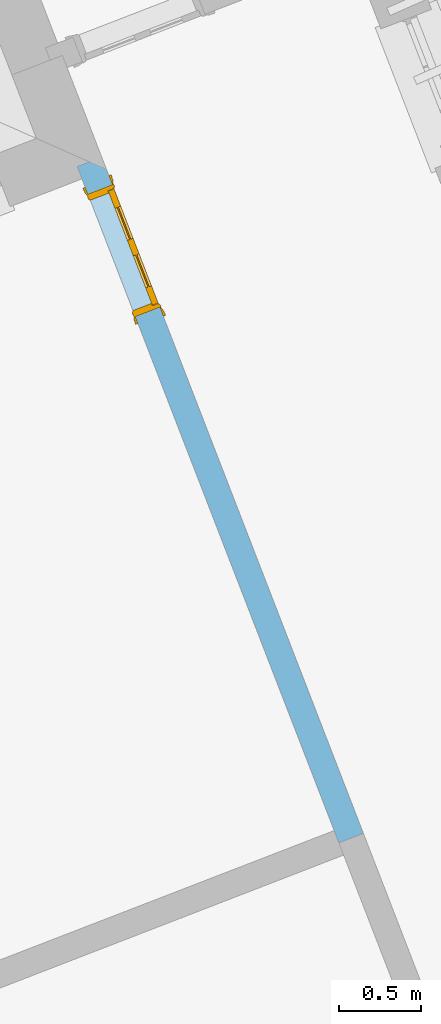
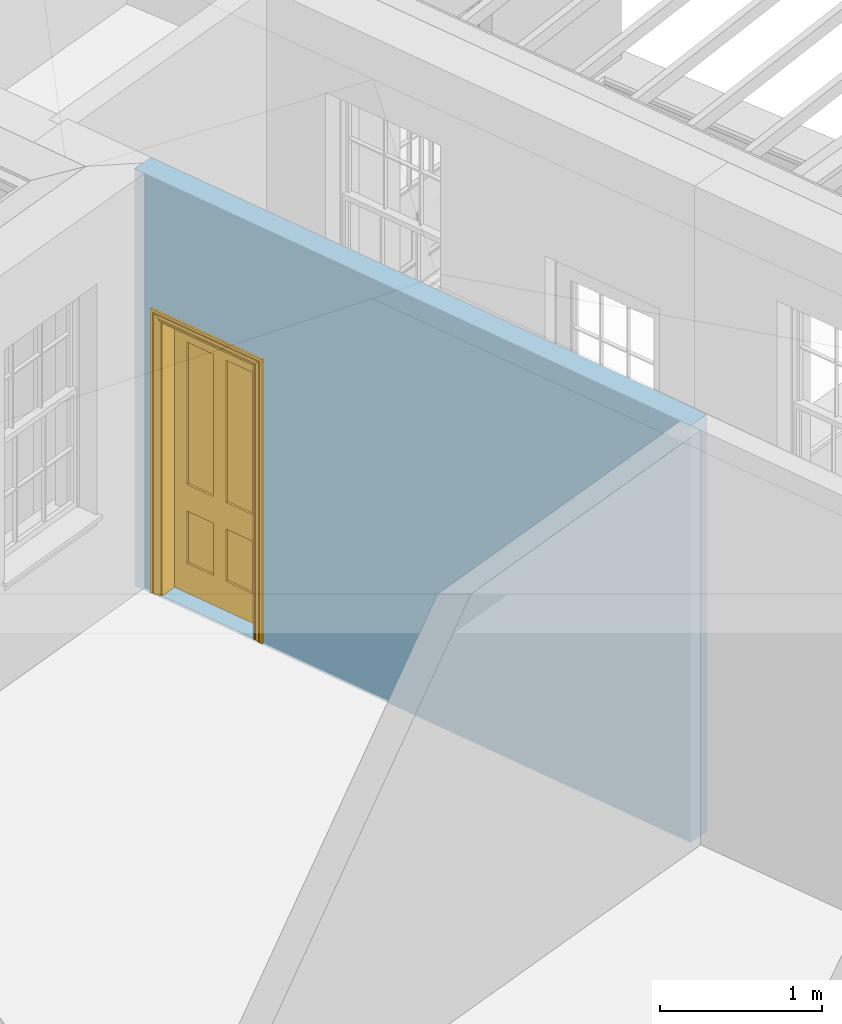
# One storey, part 5 of 11: 1 door, 1 opening, plus 1 element that does not belong to this part.
"""IFC2X3 building model written with IfcOpenShell, lengths in metres."""

import ifcopenshell
import ifcopenshell.guid

model = None  # the IFC model being written
_history = None  # IfcOwnerHistory: only IFC2X3 demands one
_inside = {}  # id of a spatial element -> (the spatial element, [elements in it])
_under = {}  # id of a project, library or spatial element -> (it, [spatial elements below it])
_declared = {}  # id of a project -> (the project, [libraries it declares])
_typed = {}  # id of a type object -> (the type object, [elements of that type])
_made_of = {}  # id of a material, layer set ... -> (it, [elements and type objects made of it])


def new_model(schema):
    """Start an empty IFC model of exactly this schema.

    Asked for "IFC4X3", IfcOpenShell would pick the latest addendum, in which some entities
    have other attributes; the version numbers below select the first issue.
    IFC2X3 requires an IfcOwnerHistory on every rooted entity: one is made here for all.
    """
    global model, _history
    if schema == "IFC4X3":
        model = ifcopenshell.file(schema_version=(4, 3, 0, 0))
    else:
        model = ifcopenshell.file(schema=schema)
    _inside.clear()
    _under.clear()
    _declared.clear()
    _typed.clear()
    _made_of.clear()
    _history = None
    if model.schema == "IFC2X3":
        org = make("IfcOrganization", Name="unknown")
        user = make(
            "IfcPersonAndOrganization",
            ThePerson=make("IfcPerson", FamilyName="unknown"),
            TheOrganization=org,
        )
        app = make(
            "IfcApplication",
            ApplicationDeveloper=org,
            Version="unknown",
            ApplicationFullName="unknown",
            ApplicationIdentifier="unknown",
        )
        _history = make(
            "IfcOwnerHistory",
            OwningUser=user,
            OwningApplication=app,
            ChangeAction="ADDED",
            CreationDate=0,
        )
    return model


def make(cls, **values):
    """One entity of the class cls with the attributes given. An attribute that is None is left unset."""
    return model.create_entity(
        cls, **{name: value for name, value in values.items() if value is not None}
    )


def rooted(cls, **values):
    """An entity with a GlobalId (a new one), such as an element, a storey or a relation."""
    return make(cls, GlobalId=ifcopenshell.guid.new(), OwnerHistory=_history, **values)


def si_unit(unit_type, name, prefix=None):
    """IfcSIUnit, for example si_unit("LENGTHUNIT", "METRE", prefix="MILLI")."""
    return make("IfcSIUnit", UnitType=unit_type, Prefix=prefix, Name=name)


def assignment(units):
    """IfcUnitAssignment: the units of a project."""
    return None if units is None else make("IfcUnitAssignment", Units=units)


def point(xyz):
    """IfcCartesianPoint."""
    return None if xyz is None else make("IfcCartesianPoint", Coordinates=xyz)


def direction(xyz):
    """IfcDirection."""
    return None if xyz is None else make("IfcDirection", DirectionRatios=xyz)


def frame(location, z_axis=None, x_axis=None):
    """IfcAxis2Placement3D, a coordinate frame: its origin and axes. An axis left out is left unset."""
    return make(
        "IfcAxis2Placement3D",
        Location=point(location),
        Axis=direction(z_axis),
        RefDirection=direction(x_axis),
    )


def origin():
    """The frame at (0, 0, 0) with its axes left unset."""
    return frame((0.0, 0.0, 0.0))


def place(relative_to, where):
    """IfcLocalPlacement: puts the frame where relative to a parent placement (None: the world)."""
    return make(
        "IfcLocalPlacement", PlacementRelTo=relative_to, RelativePlacement=where
    )


def context(
    kind, dimensions, precision=None, world=None, true_north=None, identifier=None
):
    """IfcGeometricRepresentationContext, for example the 3D "Model" context."""
    return make(
        "IfcGeometricRepresentationContext",
        ContextIdentifier=identifier,
        ContextType=kind,
        CoordinateSpaceDimension=dimensions,
        Precision=precision,
        WorldCoordinateSystem=world,
        TrueNorth=true_north,
    )


def subcontext(parent, identifier, kind, view, scale=None):
    """IfcGeometricRepresentationSubContext, for example "Body" below "Model"."""
    return make(
        "IfcGeometricRepresentationSubContext",
        ContextIdentifier=identifier,
        ContextType=kind,
        ParentContext=parent,
        TargetScale=scale,
        TargetView=view,
    )


def project(units=None, contexts=None):
    """IfcProject with its units and contexts."""
    return rooted(
        "IfcProject",
        Name="project",
        RepresentationContexts=contexts,
        UnitsInContext=assignment(units),
    )


def spatial(cls, under=None, at=None, **own):
    """A site, building, storey or space (cls), placed at a placement, below another one or the project."""
    s = rooted(cls, ObjectPlacement=at, **own)
    if under is not None:
        _under.setdefault(under.id(), (under, []))[1].append(s)
    return s


def polyline(points):
    """IfcPolyline through the points."""
    return make("IfcPolyline", Points=[point(p) for p in points])


def outline(outer, holes=None, kind="AREA"):
    """IfcArbitraryClosedProfileDef: a profile drawn as a closed curve; with holes, ...WithVoids."""
    if holes is None:
        return make("IfcArbitraryClosedProfileDef", ProfileType=kind, OuterCurve=outer)
    return make(
        "IfcArbitraryProfileDefWithVoids",
        ProfileType=kind,
        OuterCurve=outer,
        InnerCurves=holes,
    )


def extrude(swept, where, along, depth):
    """IfcExtrudedAreaSolid: the profile swept, set in the frame where, extruded along a direction by depth."""
    return make(
        "IfcExtrudedAreaSolid",
        SweptArea=swept,
        Position=where,
        ExtrudedDirection=direction(along),
        Depth=depth,
    )


def faces_of(points, faces, orient=None, outer=None):
    """IfcFace entities. A face is a list of loops; a loop is a list of indices into points, from 0.

    orient and outer hold one flag for each loop. By default every Orientation is true, the
    first loop of a face is its IfcFaceOuterBound and the others are IfcFaceBound.
    """
    made = []
    for i, loops in enumerate(faces):
        bounds = []
        for j, loop in enumerate(loops):
            is_outer = j == 0 if outer is None else outer[i][j]
            bounds.append(
                make(
                    "IfcFaceOuterBound" if is_outer else "IfcFaceBound",
                    Bound=make("IfcPolyLoop", Polygon=[points[k] for k in loop]),
                    Orientation=True if orient is None else orient[i][j],
                )
            )
        made.append(make("IfcFace", Bounds=bounds))
    return made


def faceted_brep(points, faces, orient=None, outer=None, voids=None):
    """IfcFacetedBrep: a solid bounded by flat faces; with voids (closed shells), ...WithVoids."""
    shared = [point(p) for p in points]
    hull = make("IfcClosedShell", CfsFaces=faces_of(shared, faces, orient, outer))
    if voids is None:
        return make("IfcFacetedBrep", Outer=hull)
    return make(
        "IfcFacetedBrepWithVoids",
        Outer=hull,
        Voids=[
            make(cls, CfsFaces=faces_of(shared, fs, o, b)) for cls, fs, o, b in voids
        ],
    )


def shape(context_of_items, identifier, shape_type, items):
    """IfcShapeRepresentation: the items that make up one representation, for example the "Body"."""
    return make(
        "IfcShapeRepresentation",
        ContextOfItems=context_of_items,
        RepresentationIdentifier=identifier,
        RepresentationType=shape_type,
        Items=items,
    )


def material(Name=None, Category=None):
    """IfcMaterial."""
    return make("IfcMaterial", Name=Name, Category=Category)


def layer(
    of_material, thickness, ventilated=None, Name=None, Category=None, Priority=None
):
    """IfcMaterialLayer: one layer of a wall or slab, of a material (None: an air gap)."""
    return make(
        "IfcMaterialLayer",
        Material=of_material,
        LayerThickness=thickness,
        IsVentilated=ventilated,
        Name=Name,
        Category=Category,
        Priority=Priority,
    )


def layer_set(layers, Name=None):
    """IfcMaterialLayerSet."""
    return make("IfcMaterialLayerSet", MaterialLayers=layers, LayerSetName=Name)


def layer_usage(for_layer_set, set_direction, sense, offset, extent=None):
    """IfcMaterialLayerSetUsage: how a layer set lies in its element."""
    return make(
        "IfcMaterialLayerSetUsage",
        ForLayerSet=for_layer_set,
        LayerSetDirection=set_direction,
        DirectionSense=sense,
        OffsetFromReferenceLine=offset,
        ReferenceExtent=extent,
    )


def made_of(thing, what):
    """Note that an element or type object is made of a material, layer set ...; save() writes the relation."""
    if what is not None:
        _made_of.setdefault(what.id(), (what, []))[1].append(thing)
    return thing


def element(
    cls,
    number,
    at=None,
    inside=None,
    cuts=None,
    type_object=None,
    material=None,
    context=None,
    identifier="Body",
    shape_type=None,
    held_by="IfcProductDefinitionShape",
    body=None,
    shapes=None,
    **own,
):
    """One element of the class cls, such as IfcWall. Its Tag is "e" and its number.

    at: its placement. inside: the storey or other place that contains it. cuts: it is an
    opening in that element (IfcRelVoidsElement). A single representation is given by context,
    identifier, shape_type and body (its items); several are given by shapes. held_by: the class
    of the entity that holds the representations. save() writes the other relations.
    """
    e = rooted(cls, Tag="e%d" % number, ObjectPlacement=at, **own)
    if body is not None:
        shapes = [shape(context, identifier, shape_type, body)]
    if shapes is not None:
        e.Representation = make(held_by, Representations=shapes)
    if inside is not None:
        _inside.setdefault(inside.id(), (inside, []))[1].append(e)
    if cuts is not None:
        rooted(
            "IfcRelVoidsElement", RelatingBuildingElement=cuts, RelatedOpeningElement=e
        )
    if type_object is not None:
        _typed.setdefault(type_object.id(), (type_object, []))[1].append(e)
    return made_of(e, material)


def fill(opening, filler):
    """IfcRelFillsElement: the door or window that sits in an opening."""
    return rooted(
        "IfcRelFillsElement",
        RelatingOpeningElement=opening,
        RelatedBuildingElement=filler,
    )


def aggregate(whole, parts):
    """IfcRelAggregates: a whole, such as a stair, and the parts it consists of."""
    return rooted("IfcRelAggregates", RelatingObject=whole, RelatedObjects=parts)


def save(model, path):
    """Write the relations noted so far, then the file.

    IfcRelAggregates (storeys below a building ...), IfcRelContainedInSpatialStructure (elements
    in a storey), IfcRelDefinesByType, IfcRelAssociatesMaterial and IfcRelDeclares: one each for
    every whole, place, type object, material and project.
    """
    for whole, parts in _under.values():
        aggregate(whole, parts)
    for where, things in _inside.values():
        rooted(
            "IfcRelContainedInSpatialStructure",
            RelatedElements=things,
            RelatingStructure=where,
        )
    for kind, things in _typed.values():
        rooted("IfcRelDefinesByType", RelatedObjects=things, RelatingType=kind)
    for what, things in _made_of.values():
        rooted("IfcRelAssociatesMaterial", RelatedObjects=things, RelatingMaterial=what)
    for by, libraries in _declared.values():
        rooted("IfcRelDeclares", RelatingContext=by, RelatedDefinitions=libraries)
    model.write(path)


model = new_model("IFC2X3")

# Units and contexts
model_context = context("Model", 3, world=origin())
body_context = subcontext(model_context, "Body", "Model", "MODEL_VIEW")
ifc_project = project(units=[si_unit("PLANEANGLEUNIT", "RADIAN"), si_unit("MASSUNIT", "GRAM", prefix="KILO"), si_unit("FORCEUNIT", "NEWTON", prefix="KILO"), si_unit("LENGTHUNIT", "METRE")], contexts=[model_context])

# Site, building, storey
site_placement = place(None, origin())
site = spatial("IfcSite", under=ifc_project, at=site_placement, CompositionType="ELEMENT")
building_placement = place(None, origin())
building = spatial("IfcBuilding", under=site, at=building_placement, Name="Building plot-5", CompositionType="ELEMENT")
storey_placement = place(None, frame((0.0, 0.0, 7.6)))
storey = spatial("IfcBuildingStorey", under=building, at=storey_placement, Name="Floor 1", CompositionType="ELEMENT", Elevation=7.6)

# Wall, opening, door
ifc_material = material(Name="Masonry")
ifc_layer = layer(ifc_material, 0.16, ventilated=False)
ifc_layer_set = layer_set([ifc_layer], Name="My Wall")
ifc_layer_usage = layer_usage(ifc_layer_set, "AXIS2", "NEGATIVE", 0.08)
wall_placement = place(storey_placement, origin())
wall = element("IfcWallStandardCase", 1, at=wall_placement, inside=storey, material=ifc_layer_usage, Name="interior", context=body_context, shape_type="SweptSolid", body=[
    extrude(outline(polyline([(60.3604614905425, 57.9999602248508), (60.2112438087579, 57.9422187021584), (61.8049910574457, 53.8236007871719), (61.9542087392303, 53.8813423098643), (60.3604614905425, 57.9999602248508)])), origin(), (0.0, 0.0, 1.0), 3.15),
])
opening_placement = place(storey_placement, frame((0.0, 0.0, 0.0199999999999996)))
opening = element("IfcOpeningElement", 2, at=opening_placement, cuts=wall, Name="Opening", ObjectType="Opening", context=body_context, shape_type="SweptSolid", body=[
    extrude(outline(polyline([(60.2762030217869, 57.7743488101507), (60.5649106352492, 57.028260401228), (60.7141283170337, 57.0860019239204), (60.4254207035715, 57.8320903328432), (60.2762030217869, 57.7743488101507)])), origin(), (0.0, 0.0, 1.0), 2.1),
])
door_placement = place(storey_placement, frame((60.3508118626792, 57.803219571497, 0.0199999999999996), z_axis=(0.0, 0.0, 1.0), x_axis=(0.288707613462229, -0.746088408922787, 0.0)))
door = element("IfcDoor", 3, at=door_placement, inside=storey, Name="living inside door", OverallHeight=2.1, OverallWidth=0.8, context=body_context, shape_type="Brep", held_by="IfcProductRepresentation", body=[
    faceted_brep([(0.773, 0.08, 1.895), (0.66, 0.08, 1.895), (0.66, 0.08, 2.073), (0.773, 0.08, 2.073), (0.773, 0.08, 0.82), (0.66, 0.08, 0.82), (0.45, 0.08, 1.895), (0.45, 0.08, 2.073), (0.773, 0.08, 0.62), (0.66, 0.08, 0.62), (0.66, 0.065, 0.82), (0.66, 0.065, 1.895), (0.45, 0.065, 1.895), (0.35, 0.08, 1.895), (0.35, 0.08, 2.073), (0.773, 0.08, 0.225), (0.66, 0.08, 0.225), (0.45, 0.08, 0.62), (0.45, 0.08, 0.82), (0.45, 0.065, 0.82), (0.35, 0.08, 0.82), (0.14, 0.08, 2.073), (0.14, 0.08, 1.895), (0.773, 0.08, 0.0), (0.66, 0.08, 0.0), (0.66, 0.065, 0.225), (0.66, 0.065, 0.62), (0.45, 0.065, 0.62), (0.35, 0.08, 0.62), (0.35, 0.065, 0.82), (0.35, 0.065, 1.895), (0.14, 0.065, 1.895), (0.027, 0.08, 2.073), (0.027, 0.08, 1.895), (0.773, 0.042, 0.0), (0.66, 0.042, 0.0), (0.45, 0.08, 0.0), (0.45, 0.08, 0.225), (0.45, 0.065, 0.225), (0.35, 0.08, 0.225), (0.14, 0.08, 0.82), (0.14, 0.08, 0.62), (0.14, 0.065, 0.82), (0.027, 0.08, 0.82), (0.773, 0.042, 0.225), (0.66, 0.042, 0.225), (0.45, 0.042, 0.0), (0.35, 0.08, 0.0), (0.35, 0.065, 0.225), (0.35, 0.065, 0.62), (0.14, 0.065, 0.62), (0.027, 0.08, 0.62), (0.773, 0.042, 0.62), (0.66, 0.042, 0.62), (0.45, 0.042, 0.225), (0.35, 0.042, 0.0), (0.14, 0.08, 0.225), (0.14, 0.08, 0.0), (0.14, 0.065, 0.225), (0.027, 0.08, 0.225), (0.773, 0.042, 0.82), (0.66, 0.042, 0.82), (0.66, 0.057, 0.62), (0.66, 0.057, 0.225), (0.45, 0.057, 0.225), (0.35, 0.042, 0.225), (0.14, 0.042, 0.0), (0.027, 0.08, 0.0), (0.773, 0.042, 1.895), (0.66, 0.042, 1.895), (0.45, 0.042, 0.62), (0.45, 0.042, 0.82), (0.45, 0.057, 0.62), (0.35, 0.042, 0.62), (0.14, 0.042, 0.225), (0.027, 0.042, 0.0), (0.773, 0.042, 2.073), (0.66, 0.042, 2.073), (0.66, 0.057, 1.895), (0.66, 0.057, 0.82), (0.45, 0.057, 0.82), (0.35, 0.042, 0.82), (0.35, 0.057, 0.62), (0.35, 0.057, 0.225), (0.14, 0.057, 0.225), (0.027, 0.042, 0.225), (0.45, 0.042, 1.895), (0.45, 0.042, 2.073), (0.45, 0.057, 1.895), (0.35, 0.042, 1.895), (0.14, 0.042, 0.82), (0.14, 0.042, 0.62), (0.14, 0.057, 0.62), (0.027, 0.042, 0.62), (0.35, 0.042, 2.073), (0.35, 0.057, 1.895), (0.35, 0.057, 0.82), (0.14, 0.057, 0.82), (0.027, 0.042, 0.82), (0.14, 0.042, 2.073), (0.14, 0.042, 1.895), (0.14, 0.057, 1.895), (0.027, 0.042, 1.895), (0.027, 0.042, 2.073), (0.02, 0.085, 0.0), (0.005, 0.09, 0.0), (0.005, 0.09, 2.095), (0.02, 0.085, 2.08), (0.02, 0.08, 0.0), (0.0, 0.085, 0.0), (0.0, 0.085, 2.1), (0.795, 0.09, 2.095), (0.78, 0.085, 2.08), (0.02, 0.08, 2.08), (0.0, 0.08, 0.0), (-0.032, 0.095, 0.0), (-0.032, 0.095, 2.132), (0.8, 0.085, 2.1), (0.795, 0.09, 0.0), (0.78, 0.085, 0.0), (0.78, 0.08, 2.08), (0.04, 0.04, 0.0), (0.025, 0.04, 0.0), (0.025, 0.04, 2.075), (0.04, 0.04, 2.06), (-0.04, 0.09, 0.0), (-0.04, 0.09, 2.14), (0.832, 0.095, 2.132), (0.8, 0.085, 0.0), (0.78, 0.08, 0.0), (0.8, 0.08, 0.0), (0.86, 0.08, 0.0), (0.86, 0.08, 2.16), (0.8, 0.08, 2.1), (-0.06, 0.08, 2.16), (0.0, 0.08, 2.1), (-0.06, 0.08, 0.0), (-0.04, 0.095, 0.0), (-0.04, 0.095, 2.14), (0.84, 0.09, 2.14), (0.832, 0.095, 0.0), (0.84, 0.09, 0.0), (0.86, 0.095, 0.0), (0.86, 0.095, 2.16), (-0.06, 0.095, 2.16), (-0.06, 0.095, 0.0), (0.84, 0.095, 0.0), (0.84, 0.095, 2.14), (-0.025, -0.095, 0.0), (-0.025, -0.09, 0.0), (-0.025, -0.09, 2.125), (-0.025, -0.095, 2.125), (-0.017, -0.095, 0.0), (-0.017, -0.095, 2.117), (0.825, -0.09, 2.125), (0.825, -0.095, 2.125), (0.825, -0.095, 0.0), (0.845, -0.095, 0.0), (-0.045, -0.095, 2.145), (-0.045, -0.095, 0.0), (0.845, -0.095, 2.145), (0.015, -0.085, 0.0), (0.015, -0.085, 2.085), (0.817, -0.095, 2.117), (0.825, -0.09, 0.0), (0.845, -0.08, 0.0), (0.845, -0.08, 2.145), (-0.045, -0.08, 2.145), (-0.045, -0.08, 0.0), (0.02, -0.09, 0.0), (0.02, -0.09, 2.08), (0.785, -0.085, 2.085), (0.817, -0.095, 0.0), (0.8, -0.08, 0.0), (0.8, -0.08, 2.1), (0.0, -0.08, 2.1), (0.0, -0.08, 0.0), (0.035, -0.085, 0.0), (0.035, -0.085, 2.065), (0.78, -0.09, 2.08), (0.785, -0.085, 0.0), (0.775, 0.04, 2.075), (0.76, 0.04, 2.06), (0.035, -0.08, 2.065), (0.035, -0.08, 0.0), (0.765, -0.085, 2.065), (0.78, -0.09, 0.0), (0.765, -0.08, 0.0), (0.765, -0.08, 2.065), (0.765, -0.085, 0.0), (0.04, -0.08, 2.06), (0.04, -0.08, 0.0), (0.76, -0.08, 2.06), (0.76, -0.08, 0.0), (0.76, 0.04, 0.0), (0.775, 0.04, 0.0), (0.025, 0.08, 0.0), (0.025, 0.08, 2.075), (0.775, 0.08, 0.0), (0.775, 0.08, 2.075)], [[[0, 1, 2, 3]], [[1, 0, 4, 5]], [[1, 6, 7, 2]], [[8, 9, 5, 4]], [[1, 5, 10, 11]], [[6, 1, 11, 12]], [[6, 13, 14, 7]], [[15, 16, 9, 8]], [[9, 17, 18, 5]], [[5, 18, 19, 10]], [[10, 19, 12, 11]], [[18, 6, 12, 19]], [[18, 20, 13, 6]], [[21, 14, 13, 22]], [[23, 24, 16, 15]], [[9, 16, 25, 26]], [[17, 9, 26, 27]], [[17, 28, 20, 18]], [[13, 20, 29, 30]], [[22, 13, 30, 31]], [[32, 21, 22, 33]], [[34, 35, 24, 23]], [[24, 36, 37, 16]], [[16, 37, 38, 25]], [[25, 38, 27, 26]], [[37, 17, 27, 38]], [[37, 39, 28, 17]], [[40, 20, 28, 41]], [[20, 40, 42, 29]], [[31, 30, 29, 42]], [[40, 22, 31, 42]], [[33, 22, 40, 43]], [[35, 34, 44, 45]], [[35, 46, 36, 24]], [[36, 47, 39, 37]], [[28, 39, 48, 49]], [[41, 28, 49, 50]], [[43, 40, 41, 51]], [[45, 44, 52, 53]], [[46, 35, 45, 54]], [[46, 55, 47, 36]], [[56, 39, 47, 57]], [[39, 56, 58, 48]], [[50, 49, 48, 58]], [[56, 41, 50, 58]], [[51, 41, 56, 59]], [[53, 52, 60, 61]], [[45, 53, 62, 63]], [[54, 45, 63, 64]], [[55, 46, 54, 65]], [[55, 66, 57, 47]], [[59, 56, 57, 67]], [[61, 60, 68, 69]], [[70, 53, 61, 71]], [[53, 70, 72, 62]], [[72, 64, 63, 62]], [[70, 54, 64, 72]], [[65, 54, 70, 73]], [[65, 74, 66, 55]], [[67, 57, 66, 75]], [[69, 68, 76, 77]], [[61, 69, 78, 79]], [[71, 61, 79, 80]], [[73, 70, 71, 81]], [[65, 73, 82, 83]], [[74, 65, 83, 84]], [[74, 85, 75, 66]], [[86, 69, 77, 87]], [[69, 86, 88, 78]], [[88, 80, 79, 78]], [[86, 71, 80, 88]], [[81, 71, 86, 89]], [[73, 81, 90, 91]], [[73, 91, 92, 82]], [[83, 82, 92, 84]], [[91, 74, 84, 92]], [[91, 93, 85, 74]], [[89, 86, 87, 94]], [[81, 89, 95, 96]], [[90, 81, 96, 97]], [[90, 98, 93, 91]], [[94, 99, 100, 89]], [[89, 100, 101, 95]], [[101, 97, 96, 95]], [[100, 90, 97, 101]], [[100, 102, 98, 90]], [[99, 103, 102, 100]], [[32, 103, 99, 21]], [[102, 103, 32, 33]], [[98, 102, 33, 43]], [[21, 99, 94, 14]], [[94, 87, 7, 14]], [[7, 87, 77, 2]], [[76, 3, 2, 77]], [[43, 51, 93, 98]], [[51, 59, 85, 93]], [[67, 75, 85, 59]], [[34, 23, 15, 44]], [[44, 15, 8, 52]], [[52, 8, 4, 60]], [[0, 68, 60, 4]], [[0, 3, 76, 68]], [[104, 105, 106, 107]], [[104, 108, 109, 105]], [[105, 109, 110, 106]], [[107, 106, 111, 112]], [[107, 113, 108, 104]], [[114, 109, 108]], [[109, 115, 116, 110]], [[106, 110, 117, 111]], [[112, 111, 118, 119]], [[113, 107, 112, 120]], [[121, 122, 123, 124]], [[115, 109, 114, 125]], [[115, 125, 126, 116]], [[110, 116, 127, 117]], [[111, 117, 128, 118]], [[118, 128, 129, 119]], [[120, 112, 119, 129]], [[130, 129, 128]], [[130, 131, 132, 133]], [[133, 132, 134, 135]], [[135, 134, 136, 114]], [[136, 125, 114]], [[125, 137, 138, 126]], [[116, 126, 139, 127]], [[117, 127, 140, 128]], [[141, 130, 128, 140]], [[131, 130, 141]], [[131, 142, 143, 132]], [[132, 143, 144, 134]], [[134, 144, 145, 136]], [[137, 125, 136, 145]], [[143, 142, 146]], [[143, 146, 147]], [[137, 145, 144]], [[143, 147, 138]], [[138, 137, 144]], [[143, 138, 144]], [[126, 138, 147, 139]], [[127, 139, 141, 140]], [[142, 131, 141, 146]], [[139, 147, 146, 141]], [[148, 149, 150, 151]], [[149, 152, 153, 150]], [[151, 150, 154, 155]], [[155, 156, 157]], [[158, 159, 148]], [[158, 148, 151]], [[155, 157, 160]], [[158, 151, 155]], [[155, 160, 158]], [[152, 161, 162, 153]], [[150, 153, 163, 154]], [[155, 154, 164, 156]], [[156, 164, 165, 157]], [[157, 165, 166, 160]], [[160, 166, 167, 158]], [[158, 167, 168, 159]], [[161, 169, 170, 162]], [[153, 162, 171, 163]], [[154, 163, 172, 164]], [[165, 164, 173]], [[165, 173, 174, 166]], [[166, 174, 175, 167]], [[167, 175, 176, 168]], [[169, 177, 178, 170]], [[162, 170, 179, 171]], [[163, 171, 180, 172]], [[172, 180, 173, 164]], [[124, 123, 181, 182]], [[183, 178, 177, 184]], [[170, 178, 185, 179]], [[171, 179, 186, 180]], [[187, 173, 180]], [[185, 188, 187, 189]], [[188, 185, 178, 183]], [[179, 185, 189, 186]], [[189, 187, 180, 186]], [[190, 183, 184, 191]], [[192, 188, 183, 190]], [[191, 184, 122, 121]], [[124, 190, 191, 121]], [[193, 187, 188, 192]], [[182, 192, 190, 124]], [[184, 176, 122]], [[194, 195, 187, 193]], [[192, 182, 194, 193]], [[161, 176, 184]], [[114, 108, 122, 176]], [[173, 187, 195]], [[152, 149, 176, 161]], [[169, 161, 184, 177]], [[196, 122, 108]], [[176, 175, 135, 114]], [[173, 195, 129, 130]], [[176, 149, 168]], [[123, 122, 196, 197]], [[196, 108, 113, 197]], [[175, 174, 133, 135]], [[198, 129, 195]], [[133, 174, 173, 130]], [[159, 168, 149, 148]], [[181, 123, 197, 199]], [[197, 113, 120, 199]], [[199, 120, 129, 198]], [[195, 181, 199, 198]], [[195, 194, 182, 181]]]),
])
fill(opening, door)

save(model, "model.ifc")
